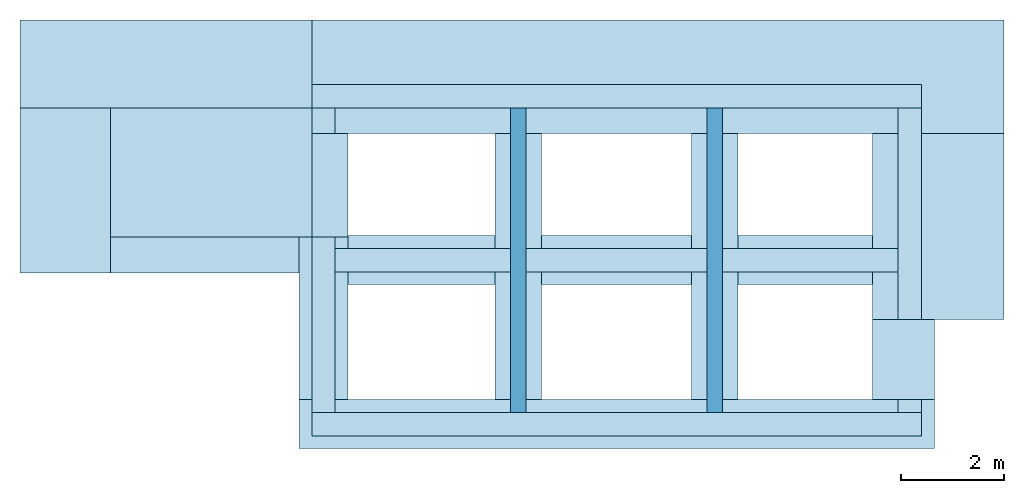
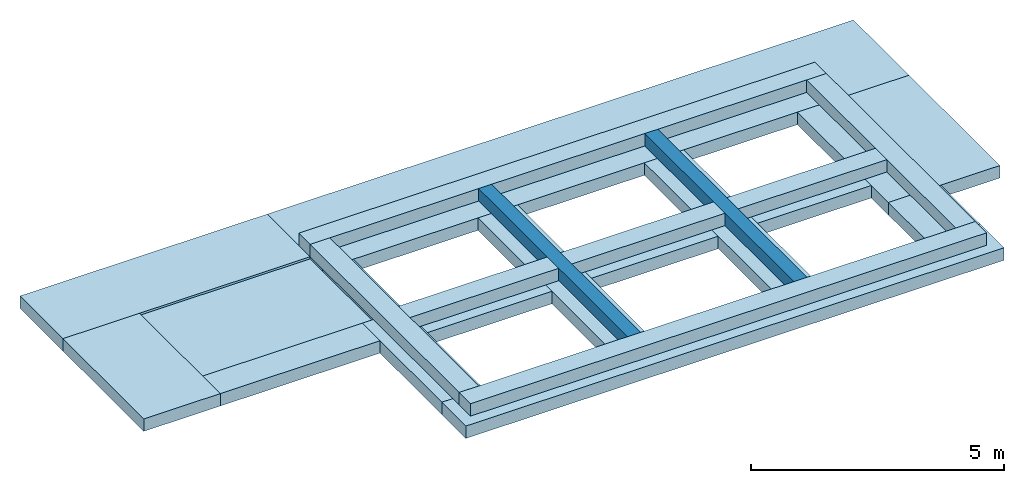
# One storey: 24 slabs.
"""IFC4 building model written with IfcOpenShell, lengths in metres."""

from ifc_helpers import new_model, entity, si_unit, converted_unit, direction, frame, frame_2d, origin_with_axes, origin_2d_with_axis, place, context, subcontext, project, spatial, rectangle, extrude, element, save


model = new_model("IFC4")

# Units and contexts
model_context = context("Model", 3, precision=1e-05, world=origin_with_axes(), true_north=direction((6.12323399573677e-17, 1.0)))
body_context = subcontext(model_context, "Body", "Model", "MODEL_VIEW")
ifc_project = project(units=[si_unit("LENGTHUNIT", "METRE"), si_unit("AREAUNIT", "SQUARE_METRE"), si_unit("VOLUMEUNIT", "CUBIC_METRE"), converted_unit("PLANEANGLEUNIT", "DEGREE", entity("IfcPlaneAngleMeasure", 0.017453292519943295), si_unit("PLANEANGLEUNIT", "RADIAN"), dimensions=[0, 0, 0, 0, 0, 0, 0])], contexts=[model_context])

# Site, building, storey
site = spatial("IfcSite", under=ifc_project, CompositionType="COMPLEX")
building = spatial("IfcBuilding", under=site, Name="Italian House", CompositionType="COMPLEX")
storey_placement = place(None, frame((0.0, 0.0, -0.759999990463257), z_axis=(0.0, 0.0, 1.0), x_axis=(1.0, 0.0, 0.0)))
storey = spatial("IfcBuildingStorey", under=building, at=storey_placement, Name="Fondazioni")

# Slabs
slab_1_placement = place(storey_placement, frame((0.0, 0.0, 0.759999990463257), z_axis=(0.0, 0.0, 1.0), x_axis=(1.0, 0.0, 0.0)))
element("IfcSlab", 1, at=slab_1_placement, inside=storey, Name="Platea001", PredefinedType="BASESLAB", context=body_context, shape_type="SweptSolid", body=[
    extrude(rectangle(XDim=5.65, YDim=1.7, at=origin_2d_with_axis()), frame((1.415, 0.51, 0.0), z_axis=(0.0, 0.0, 1.0), x_axis=(1.0, 0.0, 0.0)), (0.0, 0.0, -1.0), 0.3),
])
slab_2_placement = place(storey_placement, frame((0.0, 0.0, 0.759999990463257), z_axis=(0.0, 0.0, 1.0), x_axis=(1.0, 0.0, 0.0)))
element("IfcSlab", 2, at=slab_2_placement, inside=storey, Name="Platea002", PredefinedType="BASESLAB", context=body_context, shape_type="SweptSolid", body=[
    extrude(rectangle(XDim=13.4, YDim=2.2, at=origin_2d_with_axis()), frame((10.94, 0.26, 0.0), z_axis=(0.0, 0.0, 1.0), x_axis=(1.0, 0.0, 0.0)), (0.0, 0.0, -1.0), 0.3),
])
slab_3_placement = place(storey_placement, frame((0.0, 0.0, 0.759999990463257), z_axis=(0.0, 0.0, 1.0), x_axis=(1.0, 0.0, 0.0)))
element("IfcSlab", 3, at=slab_3_placement, inside=storey, Name="Platea003", PredefinedType="BASESLAB", context=body_context, shape_type="SweptSolid", body=[
    extrude(rectangle(XDim=1.75, YDim=3.2, at=origin_2d_with_axis()), frame((-0.535, -1.94, 0.0), z_axis=(0.0, 0.0, 1.0), x_axis=(1.0, 0.0, 0.0)), (0.0, 0.0, -1.0), 0.3),
])
slab_4_placement = place(storey_placement, frame((0.0, 0.0, 0.759999990463257), z_axis=(0.0, 0.0, 1.0), x_axis=(1.0, 0.0, 0.0)))
element("IfcSlab", 4, at=slab_4_placement, inside=storey, Name="Platea004", PredefinedType="BASESLAB", context=body_context, shape_type="SweptSolid", body=[
    extrude(rectangle(XDim=3.9, YDim=2.5, at=origin_2d_with_axis()), frame((2.29, -1.59, -0.05), z_axis=(0.0, 0.0, 1.0), x_axis=(1.0, 0.0, 0.0)), (0.0, 0.0, -1.0), 0.25),
])
slab_5_placement = place(storey_placement, frame((0.0, 0.0, 0.759999990463257), z_axis=(0.0, 0.0, 1.0), x_axis=(1.0, 0.0, 0.0)))
element("IfcSlab", 5, at=slab_5_placement, inside=storey, Name="Platea005", PredefinedType="BASESLAB", context=body_context, shape_type="SweptSolid", body=[
    extrude(rectangle(XDim=3.65, YDim=0.7, at=frame_2d((2.27373675443232e-13, 0.0), x_axis=(1.0, 0.0))), frame((2.165, -3.19, 0.0), z_axis=(0.0, 0.0, 1.0), x_axis=(1.0, 0.0, 0.0)), (0.0, 0.0, -1.0), 0.3),
])
slab_6_placement = place(storey_placement, frame((0.0, 0.0, 0.759999990463257), z_axis=(0.0, 0.0, 1.0), x_axis=(1.0, 0.0, 0.0)))
element("IfcSlab", 6, at=slab_6_placement, inside=storey, Name="Platea006", PredefinedType="BASESLAB", context=body_context, shape_type="SweptSolid", body=[
    extrude(rectangle(XDim=0.95, YDim=3.15, at=origin_2d_with_axis()), frame((4.465, -4.415, 0.0), z_axis=(0.0, 0.0, 1.0), x_axis=(1.0, 0.0, 0.0)), (0.0, 0.0, -1.0), 0.3),
])
slab_7_placement = place(storey_placement, frame((0.0, 0.0, 0.759999990463257), z_axis=(0.0, 0.0, 1.0), x_axis=(1.0, 0.0, 0.0)))
element("IfcSlab", 7, at=slab_7_placement, inside=storey, Name="Platea007", PredefinedType="BASESLAB", context=body_context, shape_type="SweptSolid", body=[
    extrude(rectangle(XDim=0.7, YDim=2.0, at=frame_2d((-5.6843418860808e-14, 0.0), x_axis=(1.0, 0.0))), frame((4.59, -1.84, 0.0), z_axis=(0.0, 0.0, 1.0), x_axis=(1.0, 0.0, 0.0)), (0.0, 0.0, -1.0), 0.3),
])
slab_8_placement = place(storey_placement, frame((0.0, 0.0, 0.759999990463257), z_axis=(0.0, 0.0, 1.0), x_axis=(1.0, 0.0, 0.0)))
element("IfcSlab", 8, at=slab_8_placement, inside=storey, Name="Platea008", PredefinedType="BASESLAB", context=body_context, shape_type="SweptSolid", body=[
    extrude(rectangle(XDim=12.3, YDim=0.95, at=origin_2d_with_axis()), frame((10.14, -6.465, 0.0), z_axis=(0.0, 0.0, 1.0), x_axis=(1.0, 0.0, 0.0)), (0.0, 0.0, -1.0), 0.3),
])
slab_9_placement = place(storey_placement, frame((0.0, 0.0, 0.759999990463257), z_axis=(0.0, 0.0, 1.0), x_axis=(1.0, 0.0, 0.0)))
element("IfcSlab", 9, at=slab_9_placement, inside=storey, Name="Platea009", PredefinedType="BASESLAB", context=body_context, shape_type="SweptSolid", body=[
    extrude(rectangle(XDim=2.55, YDim=3.6, at=origin_2d_with_axis()), frame((16.365, -2.64, 0.0), z_axis=(0.0, 0.0, 1.0), x_axis=(1.0, 0.0, 0.0)), (0.0, 0.0, -1.0), 0.3),
])
slab_10_placement = place(storey_placement, frame((0.0, 0.0, 0.759999990463257), z_axis=(0.0, 0.0, 1.0), x_axis=(1.0, 0.0, 0.0)))
element("IfcSlab", 10, at=slab_10_placement, inside=storey, Name="Platea010", PredefinedType="BASESLAB", context=body_context, shape_type="SweptSolid", body=[
    extrude(rectangle(XDim=0.9, YDim=5.15, at=origin_2d_with_axis()), frame((8.24, -3.415, 0.0), z_axis=(0.0, 0.0, 1.0), x_axis=(1.0, 0.0, 0.0)), (0.0, 0.0, -1.0), 0.3),
])
slab_11_placement = place(storey_placement, frame((0.0, 0.0, 0.759999990463257), z_axis=(0.0, 0.0, 1.0), x_axis=(1.0, 0.0, 0.0)))
element("IfcSlab", 11, at=slab_11_placement, inside=storey, Name="Platea011", PredefinedType="BASESLAB", context=body_context, shape_type="SweptSolid", body=[
    extrude(rectangle(XDim=2.85, YDim=0.95, at=frame_2d((0.0, -1.13686837721616e-13), x_axis=(1.0, 0.0))), frame((6.365, -3.29, 0.0), z_axis=(0.0, 0.0, 1.0), x_axis=(1.0, 0.0, 0.0)), (0.0, 0.0, -1.0), 0.3),
])
slab_12_placement = place(storey_placement, frame((0.0, 0.0, 0.759999990463257), z_axis=(0.0, 0.0, 1.0), x_axis=(1.0, 0.0, 0.0)))
element("IfcSlab", 12, at=slab_12_placement, inside=storey, Name="Platea012", PredefinedType="BASESLAB", context=body_context, shape_type="SweptSolid", body=[
    extrude(rectangle(XDim=1.2, YDim=1.55, at=origin_2d_with_axis()), frame((15.69, -5.215, 0.0), z_axis=(0.0, 0.0, 1.0), x_axis=(1.0, 0.0, 0.0)), (0.0, 0.0, -1.0), 0.3),
])
slab_13_placement = place(storey_placement, frame((0.0, 0.0, 0.759999990463257), z_axis=(0.0, 0.0, 1.0), x_axis=(1.0, 0.0, 0.0)))
element("IfcSlab", 13, at=slab_13_placement, inside=storey, Name="Platea013", PredefinedType="FLOOR", context=body_context, shape_type="SweptSolid", body=[
    extrude(rectangle(XDim=2.9, YDim=0.95, at=frame_2d((0.0, -5.6843418860808e-14), x_axis=(1.0, 0.0))), frame((10.14, -3.29, 0.0), z_axis=(0.0, 0.0, 1.0), x_axis=(1.0, 0.0, 0.0)), (0.0, 0.0, -1.0), 0.3),
])
slab_14_placement = place(storey_placement, frame((0.0, 0.0, 0.759999990463257), z_axis=(0.0, 0.0, 1.0), x_axis=(1.0, 0.0, 0.0)))
element("IfcSlab", 14, at=slab_14_placement, inside=storey, Name="Platea014", PredefinedType="FLOOR", context=body_context, shape_type="SweptSolid", body=[
    extrude(rectangle(XDim=0.9, YDim=5.15, at=origin_2d_with_axis()), frame((12.04, -3.415, 0.0), z_axis=(0.0, 0.0, 1.0), x_axis=(1.0, 0.0, 0.0)), (0.0, 0.0, -1.0), 0.3),
])
slab_15_placement = place(storey_placement, frame((0.0, 0.0, 0.759999990463257), z_axis=(0.0, 0.0, 1.0), x_axis=(1.0, 0.0, 0.0)))
element("IfcSlab", 15, at=slab_15_placement, inside=storey, Name="Platea015", PredefinedType="FLOOR", context=body_context, shape_type="SweptSolid", body=[
    extrude(rectangle(XDim=2.6, YDim=0.95, at=frame_2d((0.0, -5.6843418860808e-14), x_axis=(1.0, 0.0))), frame((13.79, -3.29, 0.0), z_axis=(0.0, 0.0, 1.0), x_axis=(1.0, 0.0, 0.0)), (0.0, 0.0, -1.0), 0.3),
])
slab_16_placement = place(storey_placement, frame((0.0, 0.0, 0.759999990463257), z_axis=(0.0, 0.0, 1.0), x_axis=(1.0, 0.0, 0.0)))
element("IfcSlab", 16, at=slab_16_placement, inside=storey, Name="TR001_1", PredefinedType="FLOOR", context=body_context, shape_type="SweptSolid", body=[
    extrude(rectangle(XDim=11.8, YDim=0.45, at=origin_2d_with_axis()), frame((10.14, -0.115, 0.3), z_axis=(0.0, 0.0, 1.0), x_axis=(1.0, 0.0, 0.0)), (0.0, 0.0, -1.0), 0.3),
])
slab_17_placement = place(storey_placement, frame((0.0, 0.0, 0.759999990463257), z_axis=(0.0, 0.0, 1.0), x_axis=(1.0, 0.0, 0.0)))
element("IfcSlab", 17, at=slab_17_placement, inside=storey, Name="TR002_1", PredefinedType="FLOOR", context=body_context, shape_type="SweptSolid", body=[
    extrude(rectangle(XDim=3.4, YDim=0.45, at=origin_2d_with_axis()), frame((13.89, -3.29, 0.3), z_axis=(0.0, 0.0, 1.0), x_axis=(1.0, 0.0, 0.0)), (0.0, 0.0, -1.0), 0.3),
])
slab_18_placement = place(storey_placement, frame((0.0, 0.0, 0.759999990463257), z_axis=(0.0, 0.0, 1.0), x_axis=(1.0, 0.0, 0.0)))
element("IfcSlab", 18, at=slab_18_placement, inside=storey, Name="TR002_2", PredefinedType="FLOOR", context=body_context, shape_type="SweptSolid", body=[
    extrude(rectangle(XDim=3.5, YDim=0.45, at=origin_2d_with_axis()), frame((10.14, -3.29, 0.3), z_axis=(0.0, 0.0, 1.0), x_axis=(1.0, 0.0, 0.0)), (0.0, 0.0, -1.0), 0.3),
])
slab_19_placement = place(storey_placement, frame((0.0, 0.0, 0.759999990463257), z_axis=(0.0, 0.0, 1.0), x_axis=(1.0, 0.0, 0.0)))
element("IfcSlab", 19, at=slab_19_placement, inside=storey, Name="TR002_3", PredefinedType="FLOOR", context=body_context, shape_type="SweptSolid", body=[
    extrude(rectangle(XDim=3.4, YDim=0.45, at=origin_2d_with_axis()), frame((6.39, -3.29, 0.3), z_axis=(0.0, 0.0, 1.0), x_axis=(1.0, 0.0, 0.0)), (0.0, 0.0, -1.0), 0.3),
])
slab_20_placement = place(storey_placement, frame((0.0, 0.0, 0.759999990463257), z_axis=(0.0, 0.0, 1.0), x_axis=(1.0, 0.0, 0.0)))
element("IfcSlab", 20, at=slab_20_placement, inside=storey, Name="TR003", PredefinedType="FLOOR", context=body_context, shape_type="SweptSolid", body=[
    extrude(rectangle(XDim=11.8, YDim=0.45, at=frame_2d((0.0, -2.8421709430404e-14), x_axis=(1.0, 0.0))), frame((10.14, -6.465, 0.3), z_axis=(0.0, 0.0, 1.0), x_axis=(1.0, 0.0, 0.0)), (0.0, 0.0, -1.0), 0.3),
])
slab_21_placement = place(storey_placement, frame((0.0, 0.0, 0.759999990463257), z_axis=(0.0, 0.0, 1.0), x_axis=(1.0, 0.0, 0.0)))
element("IfcSlab", 21, at=slab_21_placement, inside=storey, Name="TR004", PredefinedType="FLOOR", context=body_context, shape_type="SweptSolid", body=[
    extrude(rectangle(XDim=0.45, YDim=5.9, at=origin_2d_with_axis()), frame((4.465, -3.29, 0.3), z_axis=(0.0, 0.0, 1.0), x_axis=(1.0, 0.0, 0.0)), (0.0, 0.0, -1.0), 0.3),
])
slab_22_placement = place(storey_placement, frame((0.0, 0.0, 0.759999990463257), z_axis=(0.0, 0.0, 1.0), x_axis=(1.0, 0.0, 0.0)))
element("IfcSlab", 22, at=slab_22_placement, inside=storey, Name="TR005", PredefinedType="FLOOR", context=body_context, shape_type="SweptSolid", body=[
    extrude(rectangle(XDim=0.3, YDim=5.9, at=origin_2d_with_axis()), frame((8.24, -3.29, 0.3), z_axis=(0.0, 0.0, 1.0), x_axis=(1.0, 0.0, 0.0)), (0.0, 0.0, -1.0), 0.3),
])
slab_23_placement = place(storey_placement, frame((0.0, 0.0, 0.759999990463257), z_axis=(0.0, 0.0, 1.0), x_axis=(1.0, 0.0, 0.0)))
element("IfcSlab", 23, at=slab_23_placement, inside=storey, Name="TR006", PredefinedType="FLOOR", context=body_context, shape_type="SweptSolid", body=[
    extrude(rectangle(XDim=0.3, YDim=5.9, at=origin_2d_with_axis()), frame((12.04, -3.29, 0.3), z_axis=(0.0, 0.0, 1.0), x_axis=(1.0, 0.0, 0.0)), (0.0, 0.0, -1.0), 0.3),
])
slab_24_placement = place(storey_placement, frame((0.0, 0.0, 0.759999990463257), z_axis=(0.0, 0.0, 1.0), x_axis=(1.0, 0.0, 0.0)))
element("IfcSlab", 24, at=slab_24_placement, inside=storey, Name="TR007", PredefinedType="FLOOR", context=body_context, shape_type="SweptSolid", body=[
    extrude(rectangle(XDim=0.45, YDim=5.9, at=origin_2d_with_axis()), frame((15.815, -3.29, 0.3), z_axis=(0.0, 0.0, 1.0), x_axis=(1.0, 0.0, 0.0)), (0.0, 0.0, -1.0), 0.3),
])

save(model, "model.ifc")
